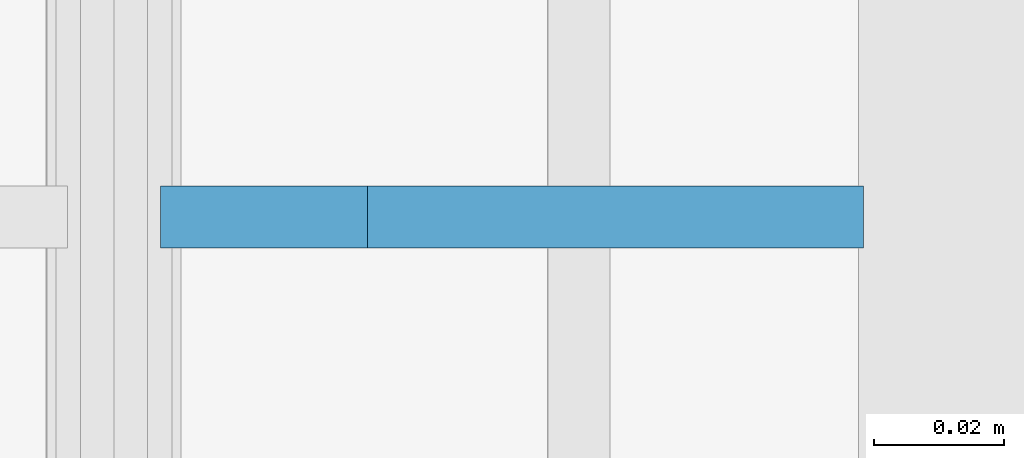
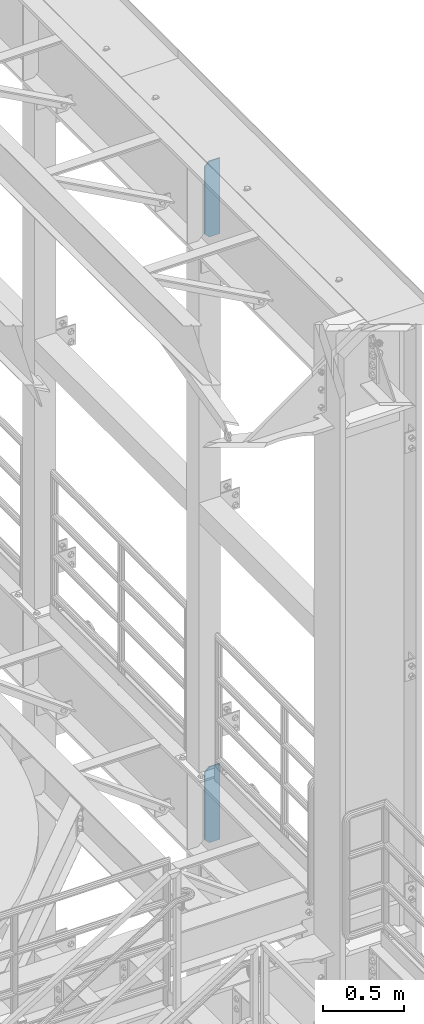
# One storey, part 1530 of 1876: 2 plates, 2 elements without a shape of their own.
"""IFC2X3 building model written with IfcOpenShell, lengths in millimetres."""

from ifc_helpers import new_model, si_unit, frame, origin_with_axes, place, context, subcontext, project, spatial, faceted_brep, material, type_object, element, aggregate, save


model = new_model("IFC2X3")

# Units and contexts
model_context = context("Model", 3, precision=1e-05, world=origin_with_axes())
body_context = subcontext(model_context, "Body", "Model", "MODEL_VIEW")
ifc_project = project(units=[si_unit("LENGTHUNIT", "METRE", prefix="MILLI"), si_unit("AREAUNIT", "SQUARE_METRE"), si_unit("VOLUMEUNIT", "CUBIC_METRE"), si_unit("MASSUNIT", "GRAM", prefix="KILO"), si_unit("TIMEUNIT", "SECOND"), si_unit("PLANEANGLEUNIT", "RADIAN"), si_unit("SOLIDANGLEUNIT", "STERADIAN"), si_unit("THERMODYNAMICTEMPERATUREUNIT", "DEGREE_CELSIUS"), si_unit("LUMINOUSINTENSITYUNIT", "LUMEN")], contexts=[model_context])

# Site, building, storey
site_placement = place(None, origin_with_axes())
site = spatial("IfcSite", under=ifc_project, at=site_placement, CompositionType="ELEMENT")
building_placement = place(site_placement, origin_with_axes())
building = spatial("IfcBuilding", under=site, at=building_placement, Name="Undefined", CompositionType="ELEMENT")
storey_placement = place(building_placement, origin_with_axes())
storey = spatial("IfcBuildingStorey", under=building, at=storey_placement, Name="Undefined", CompositionType="ELEMENT", Elevation=0.0)

# Assembly, plate
assembly_1_placement = place(storey_placement, origin_with_axes())
assembly_1 = element("IfcElementAssembly", 1, at=assembly_1_placement, inside=storey, Name="BEAM", AssemblyPlace="NOTDEFINED", PredefinedType="RIGID_FRAME")
ifc_material = material(Name="STEEL/A36")
plate_type = type_object("IfcPlateType", PredefinedType="NOTDEFINED")
plate_1_placement = place(assembly_1_placement, frame((7735.09375, -2540.0, 21958.3), z_axis=(0.0, 0.0, 1.0), x_axis=(-1.0, 0.0, 0.0)))
plate_1 = element("IfcPlate", 2, at=plate_1_placement, type_object=plate_type, material=ifc_material, Name="PLATE", context=body_context, shape_type="Brep", body=[
    faceted_brep([(0.0, -4.76249999999982, 0.0), (0.0, -4.76249999999982, 571.5), (0.0, 4.76249999999982, 571.5), (0.0, 4.76249999999982, 0.0), (76.1999969482422, -4.76249999999982, 571.5), (76.1999969482422, 4.76249999999982, 571.5), (107.949996948242, -4.76249999999982, 539.75), (107.949996948242, 4.76249999999982, 539.75), (107.949996948242, -4.76249999999982, 31.75), (107.949996948242, 4.76249999999982, 31.75), (76.1999969482422, -4.76250000000073, 0.0), (76.1999969482422, 4.76250000000073, 0.0)], [[[0, 1, 2, 3]], [[1, 4, 5, 2]], [[4, 6, 7, 5]], [[6, 8, 9, 7]], [[8, 10, 11, 9]], [[10, 0, 3, 11]], [[5, 7, 9, 11, 3, 2]], [[10, 8, 6, 4, 1, 0]]]),
])
aggregate(assembly_1, [plate_1])

assembly_2_placement = place(storey_placement, origin_with_axes())
assembly_2 = element("IfcElementAssembly", 3, at=assembly_2_placement, inside=storey, Name="BEAM", AssemblyPlace="NOTDEFINED", PredefinedType="RIGID_FRAME")
plate_2_placement = place(assembly_2_placement, frame((7735.09375, -2540.0, 17386.3), z_axis=(0.0, 0.0, 1.0), x_axis=(-1.0, 0.0, 0.0)))
plate_2 = element("IfcPlate", 4, at=plate_2_placement, type_object=plate_type, material=ifc_material, Name="PLATE", context=body_context, shape_type="Brep", body=[
    faceted_brep([(0.0, -4.76249999999982, 0.0), (0.0, -4.76249999999982, 571.5), (0.0, 4.76249999999982, 571.5), (0.0, 4.76249999999982, 0.0), (76.1999969482422, -4.76249999999982, 571.5), (76.1999969482422, 4.76249999999982, 571.5), (107.949996948242, -4.76249999999982, 539.75), (107.949996948242, 4.76249999999982, 539.75), (107.949996948242, -4.76249999999982, 31.75), (107.949996948242, 4.76249999999982, 31.75), (76.1999969482422, -4.76250000000073, 0.0), (76.1999969482422, 4.76250000000073, 0.0)], [[[0, 1, 2, 3]], [[1, 4, 5, 2]], [[4, 6, 7, 5]], [[6, 8, 9, 7]], [[8, 10, 11, 9]], [[10, 0, 3, 11]], [[5, 7, 9, 11, 3, 2]], [[10, 8, 6, 4, 1, 0]]]),
])
aggregate(assembly_2, [plate_2])

save(model, "model.ifc")
